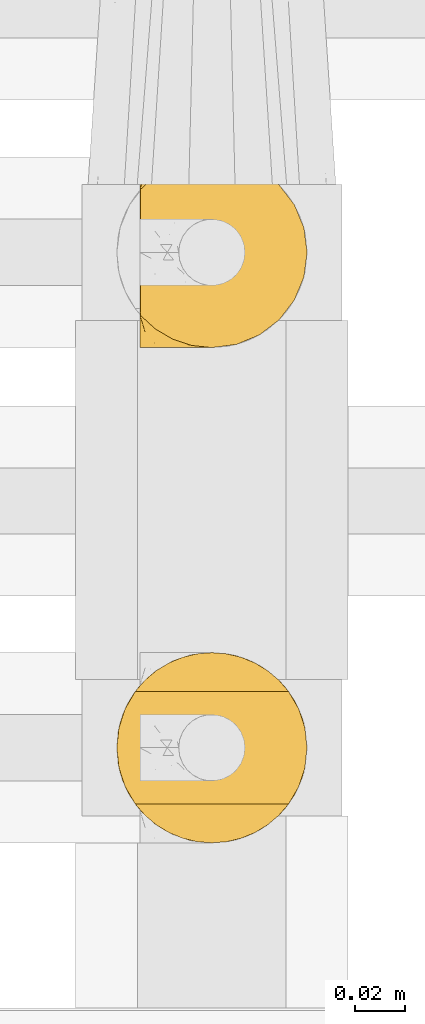
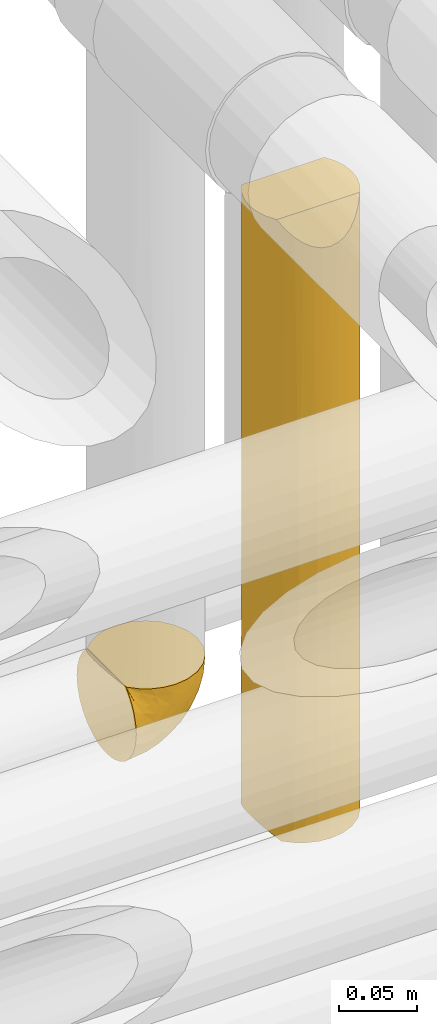
# One storey, part 343 of 827: 2 coverings.
"""IFC2X3 building model written with IfcOpenShell, lengths in millimetres."""

import ifcopenshell
import ifcopenshell.guid

model = None  # the IFC model being written
_history = None  # IfcOwnerHistory: only IFC2X3 demands one
_inside = {}  # id of a spatial element -> (the spatial element, [elements in it])
_under = {}  # id of a project, library or spatial element -> (it, [spatial elements below it])
_declared = {}  # id of a project -> (the project, [libraries it declares])
_typed = {}  # id of a type object -> (the type object, [elements of that type])
_made_of = {}  # id of a material, layer set ... -> (it, [elements and type objects made of it])


def new_model(schema):
    """Start an empty IFC model of exactly this schema.

    Asked for "IFC4X3", IfcOpenShell would pick the latest addendum, in which some entities
    have other attributes; the version numbers below select the first issue.
    IFC2X3 requires an IfcOwnerHistory on every rooted entity: one is made here for all.
    """
    global model, _history
    if schema == "IFC4X3":
        model = ifcopenshell.file(schema_version=(4, 3, 0, 0))
    else:
        model = ifcopenshell.file(schema=schema)
    _inside.clear()
    _under.clear()
    _declared.clear()
    _typed.clear()
    _made_of.clear()
    _history = None
    if model.schema == "IFC2X3":
        org = make("IfcOrganization", Name="unknown")
        user = make(
            "IfcPersonAndOrganization",
            ThePerson=make("IfcPerson", FamilyName="unknown"),
            TheOrganization=org,
        )
        app = make(
            "IfcApplication",
            ApplicationDeveloper=org,
            Version="unknown",
            ApplicationFullName="unknown",
            ApplicationIdentifier="unknown",
        )
        _history = make(
            "IfcOwnerHistory",
            OwningUser=user,
            OwningApplication=app,
            ChangeAction="ADDED",
            CreationDate=0,
        )
    return model


def make(cls, **values):
    """One entity of the class cls with the attributes given. An attribute that is None is left unset."""
    return model.create_entity(
        cls, **{name: value for name, value in values.items() if value is not None}
    )


def entity(cls, *values):
    """Any entity or typed value of the class cls, its attributes in the order of the schema. None: left unset."""
    e = model.create_entity(cls)
    for i, value in enumerate(values):
        if value is not None:
            e[i] = value
    return e


def rooted(cls, **values):
    """An entity with a GlobalId (a new one), such as an element, a storey or a relation."""
    return make(cls, GlobalId=ifcopenshell.guid.new(), OwnerHistory=_history, **values)


def si_unit(unit_type, name, prefix=None):
    """IfcSIUnit, for example si_unit("LENGTHUNIT", "METRE", prefix="MILLI")."""
    return make("IfcSIUnit", UnitType=unit_type, Prefix=prefix, Name=name)


def converted_unit(unit_type, name, factor, base, dimensions=None, offset=None):
    """IfcConversionBasedUnit, such as the inch: factor (a typed value) times the base unit."""
    return make(
        "IfcConversionBasedUnit"
        if offset is None
        else "IfcConversionBasedUnitWithOffset",
        ConversionOffset=offset,
        Dimensions=None
        if dimensions is None
        else entity("IfcDimensionalExponents", *dimensions),
        UnitType=unit_type,
        Name=name,
        ConversionFactor=make(
            "IfcMeasureWithUnit", ValueComponent=factor, UnitComponent=base
        ),
    )


def derived_unit(unit_type, elements):
    """IfcDerivedUnit: a product of units, each with its exponent."""
    return make(
        "IfcDerivedUnit",
        Elements=[
            make("IfcDerivedUnitElement", Unit=unit, Exponent=power)
            for unit, power in elements
        ],
        UnitType=unit_type,
    )


def assignment(units):
    """IfcUnitAssignment: the units of a project."""
    return None if units is None else make("IfcUnitAssignment", Units=units)


def point(xyz):
    """IfcCartesianPoint."""
    return None if xyz is None else make("IfcCartesianPoint", Coordinates=xyz)


def direction(xyz):
    """IfcDirection."""
    return None if xyz is None else make("IfcDirection", DirectionRatios=xyz)


def frame(location, z_axis=None, x_axis=None):
    """IfcAxis2Placement3D, a coordinate frame: its origin and axes. An axis left out is left unset."""
    return make(
        "IfcAxis2Placement3D",
        Location=point(location),
        Axis=direction(z_axis),
        RefDirection=direction(x_axis),
    )


def origin():
    """The frame at (0, 0, 0) with its axes left unset."""
    return frame((0.0, 0.0, 0.0))


def place(relative_to, where):
    """IfcLocalPlacement: puts the frame where relative to a parent placement (None: the world)."""
    return make(
        "IfcLocalPlacement", PlacementRelTo=relative_to, RelativePlacement=where
    )


def context(
    kind, dimensions, precision=None, world=None, true_north=None, identifier=None
):
    """IfcGeometricRepresentationContext, for example the 3D "Model" context."""
    return make(
        "IfcGeometricRepresentationContext",
        ContextIdentifier=identifier,
        ContextType=kind,
        CoordinateSpaceDimension=dimensions,
        Precision=precision,
        WorldCoordinateSystem=world,
        TrueNorth=true_north,
    )


def subcontext(parent, identifier, kind, view, scale=None):
    """IfcGeometricRepresentationSubContext, for example "Body" below "Model"."""
    return make(
        "IfcGeometricRepresentationSubContext",
        ContextIdentifier=identifier,
        ContextType=kind,
        ParentContext=parent,
        TargetScale=scale,
        TargetView=view,
    )


def project(units=None, contexts=None):
    """IfcProject with its units and contexts."""
    return rooted(
        "IfcProject",
        Name="project",
        RepresentationContexts=contexts,
        UnitsInContext=assignment(units),
    )


def spatial(cls, under=None, at=None, **own):
    """A site, building, storey or space (cls), placed at a placement, below another one or the project."""
    s = rooted(cls, ObjectPlacement=at, **own)
    if under is not None:
        _under.setdefault(under.id(), (under, []))[1].append(s)
    return s


def faces_of(points, faces, orient=None, outer=None):
    """IfcFace entities. A face is a list of loops; a loop is a list of indices into points, from 0.

    orient and outer hold one flag for each loop. By default every Orientation is true, the
    first loop of a face is its IfcFaceOuterBound and the others are IfcFaceBound.
    """
    made = []
    for i, loops in enumerate(faces):
        bounds = []
        for j, loop in enumerate(loops):
            is_outer = j == 0 if outer is None else outer[i][j]
            bounds.append(
                make(
                    "IfcFaceOuterBound" if is_outer else "IfcFaceBound",
                    Bound=make("IfcPolyLoop", Polygon=[points[k] for k in loop]),
                    Orientation=True if orient is None else orient[i][j],
                )
            )
        made.append(make("IfcFace", Bounds=bounds))
    return made


def faceted_brep(points, faces, orient=None, outer=None, voids=None):
    """IfcFacetedBrep: a solid bounded by flat faces; with voids (closed shells), ...WithVoids."""
    shared = [point(p) for p in points]
    hull = make("IfcClosedShell", CfsFaces=faces_of(shared, faces, orient, outer))
    if voids is None:
        return make("IfcFacetedBrep", Outer=hull)
    return make(
        "IfcFacetedBrepWithVoids",
        Outer=hull,
        Voids=[
            make(cls, CfsFaces=faces_of(shared, fs, o, b)) for cls, fs, o, b in voids
        ],
    )


def shape(context_of_items, identifier, shape_type, items):
    """IfcShapeRepresentation: the items that make up one representation, for example the "Body"."""
    return make(
        "IfcShapeRepresentation",
        ContextOfItems=context_of_items,
        RepresentationIdentifier=identifier,
        RepresentationType=shape_type,
        Items=items,
    )


def made_of(thing, what):
    """Note that an element or type object is made of a material, layer set ...; save() writes the relation."""
    if what is not None:
        _made_of.setdefault(what.id(), (what, []))[1].append(thing)
    return thing


def element(
    cls,
    number,
    at=None,
    inside=None,
    cuts=None,
    type_object=None,
    material=None,
    context=None,
    identifier="Body",
    shape_type=None,
    held_by="IfcProductDefinitionShape",
    body=None,
    shapes=None,
    **own,
):
    """One element of the class cls, such as IfcWall. Its Tag is "e" and its number.

    at: its placement. inside: the storey or other place that contains it. cuts: it is an
    opening in that element (IfcRelVoidsElement). A single representation is given by context,
    identifier, shape_type and body (its items); several are given by shapes. held_by: the class
    of the entity that holds the representations. save() writes the other relations.
    """
    e = rooted(cls, Tag="e%d" % number, ObjectPlacement=at, **own)
    if body is not None:
        shapes = [shape(context, identifier, shape_type, body)]
    if shapes is not None:
        e.Representation = make(held_by, Representations=shapes)
    if inside is not None:
        _inside.setdefault(inside.id(), (inside, []))[1].append(e)
    if cuts is not None:
        rooted(
            "IfcRelVoidsElement", RelatingBuildingElement=cuts, RelatedOpeningElement=e
        )
    if type_object is not None:
        _typed.setdefault(type_object.id(), (type_object, []))[1].append(e)
    return made_of(e, material)


def aggregate(whole, parts):
    """IfcRelAggregates: a whole, such as a stair, and the parts it consists of."""
    return rooted("IfcRelAggregates", RelatingObject=whole, RelatedObjects=parts)


def save(model, path):
    """Write the relations noted so far, then the file.

    IfcRelAggregates (storeys below a building ...), IfcRelContainedInSpatialStructure (elements
    in a storey), IfcRelDefinesByType, IfcRelAssociatesMaterial and IfcRelDeclares: one each for
    every whole, place, type object, material and project.
    """
    for whole, parts in _under.values():
        aggregate(whole, parts)
    for where, things in _inside.values():
        rooted(
            "IfcRelContainedInSpatialStructure",
            RelatedElements=things,
            RelatingStructure=where,
        )
    for kind, things in _typed.values():
        rooted("IfcRelDefinesByType", RelatedObjects=things, RelatingType=kind)
    for what, things in _made_of.values():
        rooted("IfcRelAssociatesMaterial", RelatedObjects=things, RelatingMaterial=what)
    for by, libraries in _declared.values():
        rooted("IfcRelDeclares", RelatingContext=by, RelatedDefinitions=libraries)
    model.write(path)


model = new_model("IFC2X3")

# Units and contexts
model_context = context("Model", 3, precision=0.01, world=origin(), true_north=direction((6.12303176911189e-17, 1.0)))
body_context = subcontext(model_context, "Body", "Model", "MODEL_VIEW")
ifc_project = project(units=[si_unit("LENGTHUNIT", "METRE", prefix="MILLI"), si_unit("AREAUNIT", "SQUARE_METRE"), si_unit("VOLUMEUNIT", "CUBIC_METRE"), converted_unit("PLANEANGLEUNIT", "DEGREE", entity("IfcRatioMeasure", 0.0174532925199433), si_unit("PLANEANGLEUNIT", "RADIAN"), dimensions=[0, 0, 0, 0, 0, 0, 0]), si_unit("MASSUNIT", "GRAM", prefix="KILO"), derived_unit("MASSDENSITYUNIT", [(si_unit("MASSUNIT", "GRAM", prefix="KILO"), 1), (si_unit("LENGTHUNIT", "METRE"), -3)]), derived_unit("MOMENTOFINERTIAUNIT", [(si_unit("LENGTHUNIT", "METRE"), 4)]), si_unit("TIMEUNIT", "SECOND"), si_unit("FREQUENCYUNIT", "HERTZ"), si_unit("THERMODYNAMICTEMPERATUREUNIT", "DEGREE_CELSIUS"), derived_unit("THERMALTRANSMITTANCEUNIT", [(si_unit("MASSUNIT", "GRAM", prefix="KILO"), 1), (si_unit("THERMODYNAMICTEMPERATUREUNIT", "KELVIN"), -1), (si_unit("TIMEUNIT", "SECOND"), -3)]), derived_unit("VOLUMETRICFLOWRATEUNIT", [(si_unit("LENGTHUNIT", "METRE"), 3), (si_unit("TIMEUNIT", "SECOND"), -1)]), derived_unit("MASSFLOWRATEUNIT", [(si_unit("MASSUNIT", "GRAM", prefix="KILO"), 1), (si_unit("TIMEUNIT", "SECOND"), -1)]), derived_unit("ROTATIONALFREQUENCYUNIT", [(si_unit("TIMEUNIT", "SECOND"), -1)]), si_unit("ELECTRICCURRENTUNIT", "AMPERE"), si_unit("ELECTRICVOLTAGEUNIT", "VOLT"), si_unit("POWERUNIT", "WATT"), si_unit("FORCEUNIT", "NEWTON", prefix="KILO"), si_unit("ILLUMINANCEUNIT", "LUX"), si_unit("LUMINOUSFLUXUNIT", "LUMEN"), si_unit("LUMINOUSINTENSITYUNIT", "CANDELA"), derived_unit("USERDEFINED", [(si_unit("MASSUNIT", "GRAM", prefix="KILO"), -1), (si_unit("LENGTHUNIT", "METRE"), -2), (si_unit("TIMEUNIT", "SECOND"), 3), (si_unit("LUMINOUSFLUXUNIT", "LUMEN"), 1)]), derived_unit("LINEARVELOCITYUNIT", [(si_unit("LENGTHUNIT", "METRE"), 1), (si_unit("TIMEUNIT", "SECOND"), -1)]), si_unit("PRESSUREUNIT", "PASCAL"), derived_unit("USERDEFINED", [(si_unit("LENGTHUNIT", "METRE"), -2), (si_unit("MASSUNIT", "GRAM", prefix="KILO"), 1), (si_unit("TIMEUNIT", "SECOND"), -2)]), derived_unit("LINEARFORCEUNIT", [(si_unit("MASSUNIT", "GRAM", prefix="KILO"), 1), (si_unit("LENGTHUNIT", "METRE"), 1), (si_unit("TIMEUNIT", "SECOND"), -2), (si_unit("LENGTHUNIT", "METRE"), -1)]), derived_unit("PLANARFORCEUNIT", [(si_unit("MASSUNIT", "GRAM", prefix="KILO"), 1), (si_unit("LENGTHUNIT", "METRE"), 1), (si_unit("TIMEUNIT", "SECOND"), -2), (si_unit("LENGTHUNIT", "METRE"), -2)])], contexts=[model_context])

# Site, building, storey
site_placement = place(None, origin())
site = spatial("IfcSite", under=ifc_project, at=site_placement, CompositionType="ELEMENT")
building_placement = place(site_placement, origin())
building = spatial("IfcBuilding", under=site, at=building_placement, CompositionType="ELEMENT")
storey_placement = place(building_placement, frame((0.0, 0.0, 28200.0)))
storey = spatial("IfcBuildingStorey", under=building, at=storey_placement, Name="08", CompositionType="ELEMENT", Elevation=28200.0)

# Coverings
covering_1_placement = place(storey_placement, frame((36438.02, 15449.95, 2959.95)))
element("IfcCovering", 1, at=covering_1_placement, inside=storey, Name=":ADSK_", ObjectType=":ADSK_", PredefinedType="INSULATION", context=body_context, shape_type="Brep", body=[
    faceted_brep([(1.6, 74.68, 23.36), (1.6, 70.1, 16.07), (1.6, 64.01, 9.98), (1.6, 56.72, 5.4), (1.6, 48.6, 2.56), (1.6, 40.05, 1.6), (1.6, 31.49, 2.56), (1.6, 23.36, 5.41), (1.6, 16.07, 9.99), (1.6, 9.98, 16.08), (1.6, 5.4, 23.37), (1.6, 2.56, 31.49), (1.6, 1.6, 40.05), (1.6, 2.46, 48.15), (1.6, 5.01, 55.88), (1.6, 9.13, 62.9), (1.6, 14.62, 68.89), (1.6, 16.82, 68.89), (1.6, 18.56, 68.89), (1.6, 20.52, 68.89), (1.6, 22.49, 68.89), (1.6, 24.46, 68.89), (1.6, 26.42, 68.89), (1.6, 28.39, 68.89), (1.6, 30.36, 68.89), (1.6, 32.55, 68.89), (1.6, 34.75, 68.89), (1.6, 36.94, 68.89), (1.6, 39.13, 68.89), (1.6, 41.33, 68.89), (1.6, 43.52, 68.89), (1.6, 45.72, 68.89), (1.6, 47.91, 68.89), (1.6, 50.11, 68.89), (1.6, 52.3, 68.89), (1.6, 54.49, 68.89), (1.6, 56.69, 68.89), (1.6, 58.88, 68.89), (1.6, 61.08, 68.89), (1.6, 63.27, 68.89), (1.6, 65.47, 68.89), (1.6, 70.97, 62.89), (1.6, 75.09, 55.86), (1.6, 77.64, 48.13), (1.6, 78.5, 40.05), (1.6, 77.53, 31.49), (1.85, 14.62, 69.15), (7.85, 9.12, 69.15), (14.87, 5.0, 69.15), (22.6, 2.46, 69.15), (30.7, 1.6, 69.15), (40.65, 2.91, 69.15), (49.92, 6.75, 69.15), (57.88, 12.86, 69.15), (63.99, 20.82, 69.15), (67.84, 30.09, 69.15), (69.15, 40.05, 69.15), (67.84, 50.0, 69.15), (63.99, 59.27, 69.15), (57.88, 67.23, 69.15), (49.92, 73.34, 69.15), (40.65, 77.19, 69.15), (30.7, 78.5, 69.15), (22.6, 77.63, 69.15), (14.87, 75.09, 69.15), (7.85, 70.97, 69.15), (1.85, 65.47, 69.15), (1.85, 63.27, 69.15), (1.85, 62.29, 69.15), (1.85, 60.7, 69.15), (1.85, 59.11, 69.15), (1.85, 57.52, 69.15), (1.85, 55.93, 69.15), (1.85, 54.34, 69.15), (1.85, 52.76, 69.15), (1.85, 51.17, 69.15), (1.85, 49.58, 69.15), (1.85, 47.99, 69.15), (1.85, 46.4, 69.15), (1.85, 44.81, 69.15), (1.85, 43.22, 69.15), (1.85, 41.63, 69.15), (1.85, 40.05, 69.15), (1.85, 38.46, 69.15), (1.85, 36.87, 69.15), (1.85, 35.28, 69.15), (1.85, 33.69, 69.15), (1.85, 32.1, 69.15), (1.85, 30.51, 69.15), (1.85, 28.92, 69.15), (1.85, 27.33, 69.15), (1.85, 25.37, 69.15), (1.85, 23.4, 69.15), (1.85, 21.21, 69.15), (1.85, 19.01, 69.15), (1.85, 16.82, 69.15), (1.77, 42.32, 68.96), (1.78, 44.02, 68.97), (1.77, 47.13, 68.97), (1.77, 48.74, 68.97), (1.76, 23.57, 68.95), (1.77, 25.13, 68.96), (1.79, 61.34, 68.98), (1.78, 22.02, 68.97), (1.78, 29.72, 68.97), (1.78, 56.73, 68.98), (1.78, 55.14, 68.97), (1.78, 37.66, 68.97), (1.74, 64.12, 68.94), (1.78, 28.13, 68.98), (1.78, 26.62, 68.98), (1.77, 31.46, 68.96), (1.78, 16.16, 68.97), (1.78, 39.16, 68.98), (1.78, 50.37, 68.98), (1.77, 17.69, 68.97), (1.77, 19.17, 68.96), (1.77, 62.78, 68.97), (1.78, 58.35, 68.97), (1.78, 45.53, 68.98), (1.77, 59.91, 68.96), (1.77, 65.47, 68.97), (1.72, 65.47, 68.94), (1.66, 65.47, 68.92), (1.77, 14.62, 68.97), (1.8, 14.62, 69.02), (1.82, 14.62, 69.08), (1.79, 20.59, 68.98), (1.78, 32.99, 68.97), (1.79, 34.48, 68.98), (1.78, 51.91, 68.97), (1.82, 65.47, 69.08), (1.8, 65.47, 69.02), (1.76, 53.48, 68.96), (1.66, 14.62, 68.92), (1.72, 14.62, 68.94), (1.78, 40.77, 68.97), (1.77, 35.97, 68.96), (9.41, 7.84, 67.02), (17.65, 3.53, 63.33), (7.41, 8.32, 64.61), (15.21, 2.19, 51.4), (7.41, 3.53, 53.1), (16.15, 1.6, 43.94), (28.75, 1.6, 61.87), (13.67, 4.57, 61.54), (12.79, 3.96, 57.95), (19.18, 2.28, 56.12), (29.16, 1.6, 63.4), (9.04, 7.69, 65.41), (5.74, 8.32, 63.04), (3.72, 7.84, 61.33), (8.87, 1.6, 41.99), (21.47, 1.6, 49.27), (26.8, 1.6, 54.6), (9.53, 4.34, 56.6), (7.34, 1.6, 41.58), (37.63, 29.63, 13.72), (17.92, 27.34, 5.82), (27.45, 40.05, 6.74), (37.01, 2.39, 58.82), (34.22, 2.43, 51.58), (45.87, 9.07, 42.09), (56.57, 16.64, 46.12), (52.31, 9.54, 55.56), (42.07, 4.52, 52.38), (44.74, 4.52, 61.54), (21.49, 7.49, 23.76), (11.02, 7.49, 20.5), (15.64, 12.85, 14.64), (26.02, 2.35, 41.77), (36.59, 22.66, 16.28), (65.49, 32.9, 49.4), (63.99, 25.33, 52.34), (15.2, 40.05, 4.3), (60.27, 16.64, 58.67), (45.25, 19.99, 25.26), (35.21, 16.37, 20.17), (22.52, 3.26, 34.7), (12.03, 3.75, 28.67), (13.32, 19.58, 8.62), (35.9, 7.5, 33.37), (33.87, 4.04, 41.35), (25.73, 13.94, 17.15), (26.34, 19.58, 12.68), (46.78, 28.21, 21.47), (59.54, 24.75, 41.11), (60.18, 31.42, 37.53), (53.93, 26.2, 30.64), (53.36, 33.36, 26.66), (49.36, 40.05, 21.38), (38.4, 40.05, 14.06), (66.44, 40.05, 55.54), (50.09, 16.14, 35.17), (41.08, 12.85, 29.04), (31.14, 10.47, 24.34), (28.19, 6.49, 29.33), (64.0, 40.05, 43.3), (56.68, 40.05, 32.34), (43.9, 75.57, 57.75), (65.46, 47.37, 49.41), (52.22, 52.91, 27.85), (37.61, 50.46, 13.7), (15.64, 67.23, 14.63), (13.31, 60.5, 8.61), (50.02, 70.55, 48.85), (59.28, 63.45, 54.13), (53.05, 62.61, 37.84), (21.48, 72.6, 23.75), (11.01, 72.6, 20.49), (12.03, 76.34, 28.66), (41.02, 59.34, 20.83), (35.39, 77.76, 55.15), (26.8, 78.5, 54.6), (28.75, 78.5, 61.87), (7.34, 78.5, 41.58), (65.81, 53.16, 57.58), (53.28, 70.55, 59.91), (59.8, 48.88, 36.94), (61.82, 54.76, 45.72), (17.91, 52.74, 5.82), (41.4, 71.93, 37.91), (40.48, 75.79, 50.18), (26.34, 60.5, 12.67), (31.68, 77.86, 49.29), (27.68, 77.64, 42.64), (16.15, 78.5, 43.94), (21.47, 78.5, 49.27), (28.05, 67.23, 19.45), (22.54, 76.82, 34.7), (8.87, 78.5, 41.99), (37.3, 77.8, 62.29), (41.07, 67.23, 29.01), (32.24, 73.2, 31.47), (47.4, 67.66, 37.18), (35.77, 75.99, 43.45), (17.65, 76.57, 63.33), (11.06, 73.21, 67.23), (8.55, 71.93, 66.07), (6.63, 71.07, 65.22), (12.77, 75.09, 61.99), (12.79, 76.13, 57.95), (7.41, 76.57, 53.09), (18.97, 77.69, 56.84), (3.72, 72.26, 61.33), (5.76, 71.77, 63.06), (15.21, 77.9, 51.41), (9.52, 75.75, 56.61)], [[[0, 1, 2, 3, 4, 5, 6, 7, 8, 9, 10, 11, 12, 13, 14, 15, 16, 17, 18, 19, 20, 21, 22, 23, 24, 25, 26, 27, 28, 29, 30, 31, 32, 33, 34, 35, 36, 37, 38, 39, 40, 41, 42, 43, 44, 45]], [[46, 47, 48, 49, 50, 51, 52, 53, 54, 55, 56, 57, 58, 59, 60, 61, 62, 63, 64, 65, 66, 67, 68, 69, 70, 71, 72, 73, 74, 75, 76, 77, 78, 79, 80, 81, 82, 83, 84, 85, 86, 87, 88, 89, 90, 91, 92, 93, 94, 95]], [[96, 97, 30]], [[98, 77, 99]], [[100, 101, 21]], [[69, 68, 102]], [[20, 19, 103]], [[24, 23, 104]], [[20, 103, 100]], [[72, 105, 106]], [[84, 83, 107]], [[89, 88, 104]], [[108, 67, 66]], [[109, 110, 90]], [[111, 25, 24]], [[112, 17, 16]], [[82, 113, 83]], [[109, 23, 22]], [[114, 76, 75]], [[105, 36, 106]], [[104, 111, 24]], [[18, 115, 116]], [[97, 96, 80]], [[67, 108, 117]], [[105, 71, 118]], [[31, 97, 119]], [[102, 120, 69]], [[108, 121, 122, 123, 40]], [[112, 95, 115]], [[17, 115, 18]], [[94, 116, 115]], [[117, 68, 67]], [[38, 117, 39]], [[112, 124, 125, 126, 46]], [[17, 112, 115]], [[70, 120, 118]], [[39, 117, 108]], [[120, 38, 37]], [[120, 37, 118]], [[120, 70, 69]], [[116, 94, 127]], [[128, 86, 129]], [[117, 38, 102]], [[74, 130, 75]], [[99, 33, 32]], [[115, 95, 94]], [[39, 108, 40]], [[108, 66, 131, 132, 121]], [[105, 72, 71]], [[118, 37, 36]], [[71, 70, 118]], [[35, 106, 36]], [[36, 105, 118]], [[35, 133, 106]], [[74, 73, 133]], [[106, 133, 73]], [[99, 114, 33]], [[133, 35, 34]], [[73, 72, 106]], [[95, 112, 46]], [[112, 16, 134, 135, 124]], [[130, 114, 75]], [[99, 76, 114]], [[114, 130, 33]], [[34, 33, 130]], [[78, 77, 98]], [[98, 119, 78]], [[130, 133, 34]], [[133, 130, 74]], [[79, 97, 80]], [[98, 99, 32]], [[98, 32, 31]], [[77, 76, 99]], [[97, 79, 119]], [[136, 96, 29]], [[30, 97, 31]], [[136, 29, 28]], [[81, 80, 96]], [[29, 96, 30]], [[31, 119, 98]], [[119, 79, 78]], [[96, 136, 81]], [[82, 81, 136]], [[113, 107, 83]], [[84, 107, 137]], [[107, 27, 137]], [[113, 28, 107]], [[27, 107, 28]], [[85, 84, 137]], [[137, 27, 26]], [[113, 136, 28]], [[136, 113, 82]], [[109, 89, 104]], [[86, 85, 129]], [[89, 109, 90]], [[111, 87, 128]], [[26, 129, 137]], [[88, 111, 104]], [[25, 111, 128]], [[22, 110, 109]], [[23, 109, 104]], [[110, 91, 90]], [[100, 92, 101]], [[110, 22, 101]], [[91, 110, 101]], [[116, 19, 18]], [[111, 88, 87]], [[127, 103, 19]], [[25, 128, 26]], [[86, 128, 87]], [[128, 129, 26]], [[137, 129, 85]], [[120, 102, 38]], [[117, 102, 68]], [[91, 101, 92]], [[21, 101, 22]], [[93, 92, 103]], [[100, 21, 20]], [[100, 103, 92]], [[127, 93, 103]], [[93, 127, 94]], [[116, 127, 19]], [[126, 138, 47]], [[48, 138, 139]], [[140, 125, 124]], [[141, 142, 143]], [[144, 49, 139]], [[145, 140, 146]], [[48, 139, 49]], [[139, 145, 147]], [[49, 144, 148, 50]], [[126, 125, 149]], [[14, 13, 142]], [[150, 146, 140]], [[149, 140, 145]], [[151, 150, 135]], [[151, 14, 142]], [[16, 15, 134]], [[13, 152, 142]], [[124, 150, 140]], [[141, 143, 153]], [[14, 151, 15]], [[15, 151, 134]], [[47, 46, 126]], [[139, 154, 144]], [[138, 48, 47]], [[125, 140, 149]], [[135, 134, 151]], [[146, 155, 141]], [[145, 146, 147]], [[149, 139, 138]], [[147, 153, 154]], [[147, 146, 141]], [[139, 147, 154]], [[139, 149, 145]], [[149, 138, 126]], [[147, 141, 153]], [[146, 150, 155]], [[151, 155, 150]], [[142, 141, 155]], [[13, 12, 156, 152]], [[152, 143, 142]], [[151, 142, 155]], [[150, 124, 135]], [[157, 158, 159]], [[160, 154, 161]], [[162, 163, 164]], [[165, 166, 160]], [[167, 168, 169]], [[153, 170, 161]], [[156, 12, 11]], [[158, 157, 171]], [[172, 55, 173]], [[158, 6, 174]], [[175, 54, 53]], [[52, 166, 164]], [[52, 164, 53]], [[54, 175, 173]], [[166, 52, 51]], [[176, 177, 171]], [[178, 143, 179]], [[156, 11, 179]], [[8, 7, 180]], [[169, 9, 8]], [[179, 143, 152, 156]], [[179, 11, 10]], [[168, 179, 10]], [[181, 162, 182]], [[179, 167, 178]], [[183, 184, 177]], [[183, 169, 184]], [[176, 171, 185]], [[172, 186, 187]], [[158, 7, 6]], [[159, 158, 174]], [[184, 180, 158]], [[54, 173, 55]], [[180, 169, 8]], [[188, 189, 187]], [[9, 168, 10]], [[186, 188, 187]], [[190, 157, 159, 191]], [[55, 172, 192]], [[176, 193, 194]], [[161, 170, 182]], [[162, 164, 165]], [[175, 164, 163]], [[51, 50, 148]], [[167, 195, 196]], [[178, 182, 170]], [[6, 5, 174]], [[158, 180, 7]], [[169, 180, 184]], [[169, 168, 9]], [[179, 168, 167]], [[182, 162, 165]], [[162, 194, 193]], [[161, 165, 160]], [[195, 181, 196]], [[192, 172, 197]], [[192, 56, 55]], [[189, 190, 198]], [[198, 197, 187]], [[172, 187, 197]], [[185, 189, 188]], [[198, 187, 189]], [[186, 172, 173]], [[173, 163, 186]], [[193, 186, 163]], [[176, 185, 188]], [[185, 157, 190]], [[188, 186, 193]], [[177, 176, 194]], [[188, 193, 176]], [[162, 193, 163]], [[195, 177, 194]], [[171, 177, 184]], [[181, 195, 194]], [[183, 167, 169]], [[162, 181, 194]], [[196, 182, 178]], [[158, 171, 184]], [[171, 157, 185]], [[177, 195, 183]], [[167, 183, 195]], [[182, 196, 181]], [[178, 170, 143]], [[178, 167, 196]], [[164, 175, 53]], [[173, 175, 163]], [[160, 51, 148]], [[164, 166, 165]], [[51, 160, 166]], [[160, 148, 144, 154]], [[153, 161, 154]], [[182, 165, 161]], [[190, 189, 185]], [[143, 170, 153]], [[60, 199, 61]], [[197, 200, 192]], [[201, 190, 202]], [[200, 57, 192]], [[203, 204, 2]], [[205, 206, 207]], [[208, 209, 210]], [[211, 207, 201]], [[212, 213, 214]], [[45, 215, 210]], [[216, 206, 58]], [[45, 44, 215]], [[59, 217, 60]], [[60, 217, 199]], [[0, 45, 210]], [[218, 201, 219]], [[202, 159, 220]], [[205, 221, 222]], [[223, 204, 203]], [[1, 203, 2]], [[57, 200, 216]], [[220, 3, 204]], [[220, 174, 4]], [[1, 0, 209]], [[212, 224, 213]], [[225, 226, 227]], [[228, 223, 203]], [[208, 210, 229]], [[210, 226, 229]], [[3, 220, 4]], [[58, 206, 59]], [[209, 203, 1]], [[202, 220, 223]], [[228, 203, 208]], [[202, 211, 201]], [[3, 2, 204]], [[202, 190, 191, 159]], [[210, 215, 230, 226]], [[199, 212, 231]], [[232, 233, 221]], [[233, 208, 229]], [[207, 206, 219]], [[217, 206, 205]], [[227, 224, 225]], [[233, 232, 228]], [[201, 207, 219]], [[234, 232, 221]], [[218, 219, 200]], [[202, 223, 211]], [[174, 220, 159]], [[174, 5, 4]], [[61, 231, 62]], [[220, 204, 223]], [[210, 209, 0]], [[203, 209, 208]], [[225, 233, 229]], [[224, 227, 213]], [[221, 233, 235]], [[57, 56, 192]], [[198, 218, 197]], [[200, 219, 216]], [[201, 198, 190]], [[197, 218, 200]], [[198, 201, 218]], [[206, 216, 219]], [[58, 57, 216]], [[231, 212, 214]], [[222, 212, 199]], [[228, 211, 223]], [[207, 211, 232]], [[62, 231, 214]], [[199, 231, 61]], [[233, 228, 208]], [[211, 228, 232]], [[222, 221, 235]], [[234, 205, 207]], [[206, 217, 59]], [[199, 217, 205]], [[205, 222, 199]], [[224, 222, 235]], [[222, 224, 212]], [[224, 235, 225]], [[233, 225, 235]], [[226, 225, 229]], [[205, 234, 221]], [[207, 232, 234]], [[63, 214, 236]], [[214, 213, 236]], [[214, 63, 62]], [[237, 236, 238]], [[238, 132, 131]], [[236, 237, 64]], [[239, 240, 241]], [[63, 236, 64]], [[131, 66, 65]], [[237, 131, 65]], [[242, 230, 43]], [[237, 65, 64]], [[239, 121, 132]], [[42, 242, 43]], [[241, 240, 243]], [[41, 123, 244]], [[43, 230, 215, 44]], [[244, 122, 245]], [[227, 246, 243]], [[241, 247, 245]], [[121, 239, 245]], [[41, 40, 123]], [[132, 238, 239]], [[244, 42, 41]], [[131, 237, 238]], [[240, 239, 238]], [[245, 239, 241]], [[247, 241, 246]], [[247, 244, 245]], [[238, 236, 240]], [[243, 236, 213]], [[236, 243, 240]], [[227, 226, 246]], [[243, 213, 227]], [[242, 246, 226]], [[243, 246, 241]], [[246, 242, 247]], [[244, 247, 242]], [[242, 226, 230]], [[42, 244, 242]], [[122, 244, 123]], [[122, 121, 245]]]),
])
covering_2_placement = place(storey_placement, frame((36428.72, 15250.0, 3027.5)))
element("IfcCovering", 2, at=covering_2_placement, inside=storey, Name=":ADSK_", ObjectType=":ADSK_", PredefinedType="INSULATION", context=body_context, shape_type="Brep", body=[
    faceted_brep([(16.91, 9.31, 1.6), (10.9, 14.94, 1.6), (10.9, 65.05, 1.6), (16.91, 70.68, 1.6), (23.98, 74.9, 1.6), (31.79, 77.51, 1.6), (40.0, 78.4, 1.6), (49.93, 77.09, 1.6), (59.2, 73.25, 1.6), (67.15, 67.15, 1.6), (73.25, 59.2, 1.6), (77.09, 49.93, 1.6), (78.4, 40.0, 1.6), (77.09, 30.06, 1.6), (73.25, 20.8, 1.6), (67.15, 12.84, 1.6), (59.2, 6.74, 1.6), (49.93, 2.9, 1.6), (40.0, 1.6, 1.6), (31.79, 2.48, 1.6), (23.98, 5.09, 1.6), (2.45, 31.93, 490.0), (4.98, 24.24, 490.0), (9.06, 17.25, 490.0), (70.93, 17.25, 490.0), (75.01, 24.24, 490.0), (77.54, 31.93, 490.0), (78.4, 40.0, 490.0), (77.54, 48.06, 490.0), (75.01, 55.75, 490.0), (70.93, 62.75, 490.0), (9.06, 62.75, 490.0), (4.98, 55.75, 490.0), (2.45, 48.06, 490.0), (1.6, 40.0, 490.0), (6.04, 22.05, 259.03), (19.86, 7.3, 235.42), (31.0, 2.66, 242.84), (10.73, 15.13, 251.9), (17.54, 8.84, 477.99), (12.97, 12.71, 483.52), (40.0, 1.6, 251.27), (22.66, 5.73, 473.55), (2.97, 29.81, 243.75), (4.0, 26.63, 8.5), (34.02, 2.06, 468.31), (40.0, 1.6, 467.64), (1.6, 40.0, 250.44), (28.2, 3.45, 470.29), (2.2, 33.21, 10.29), (6.92, 20.48, 5.57), (1.6, 40.0, 227.27), (1.6, 40.0, 10.9), (2.97, 50.18, 243.75), (2.2, 46.78, 10.29), (8.88, 62.5, 236.9), (28.2, 76.54, 470.29), (34.02, 77.93, 468.31), (32.49, 77.66, 220.4), (5.36, 56.58, 187.01), (4.0, 53.36, 8.5), (6.92, 59.51, 5.57), (40.0, 78.4, 467.64), (40.0, 78.4, 251.27), (14.98, 69.13, 243.74), (12.97, 67.28, 483.52), (17.54, 71.15, 477.99), (25.25, 75.45, 243.03), (22.66, 74.26, 473.55), (54.76, 75.45, 223.03), (47.46, 77.66, 209.58), (78.4, 40.0, 273.62), (76.48, 51.97, 255.92), (57.33, 74.26, 473.55), (62.33, 71.23, 227.69), (73.48, 58.8, 294.68), (62.45, 71.15, 477.99), (51.79, 76.54, 470.29), (45.97, 77.93, 468.31), (69.27, 64.85, 243.58), (67.02, 67.28, 483.52), (76.48, 28.02, 255.92), (73.48, 21.19, 294.68), (47.46, 2.33, 209.58), (69.27, 15.14, 243.58), (45.97, 2.06, 468.31), (67.02, 12.71, 483.52), (62.33, 8.76, 227.69), (62.45, 8.84, 477.99), (51.79, 3.45, 470.29), (54.76, 4.55, 223.03), (57.33, 5.73, 473.55)], [[[0, 1, 2, 3, 4, 5, 6, 7, 8, 9, 10, 11, 12, 13, 14, 15, 16, 17, 18, 19, 20]], [[21, 22, 23, 24, 25, 26, 27, 28, 29, 30, 31, 32, 33, 34]], [[23, 22, 35]], [[36, 20, 37]], [[38, 39, 40]], [[18, 41, 19]], [[0, 20, 36]], [[36, 37, 42]], [[35, 43, 44]], [[41, 45, 37]], [[46, 45, 41]], [[20, 19, 37]], [[47, 21, 34]], [[41, 37, 19]], [[39, 36, 42]], [[23, 35, 38]], [[39, 38, 36]], [[48, 42, 37]], [[38, 40, 23]], [[22, 21, 43]], [[43, 35, 22]], [[43, 47, 49]], [[44, 50, 35]], [[1, 38, 50]], [[37, 45, 48]], [[49, 44, 43]], [[21, 47, 43]], [[38, 1, 0]], [[50, 38, 35]], [[0, 36, 38]], [[49, 47, 51, 52]], [[33, 51, 47, 34]], [[51, 53, 54]], [[32, 31, 55]], [[56, 57, 58]], [[51, 33, 53]], [[32, 55, 59]], [[53, 59, 60]], [[2, 61, 55]], [[57, 62, 63]], [[53, 60, 54]], [[60, 59, 61]], [[64, 55, 65]], [[65, 66, 64]], [[67, 4, 3]], [[67, 66, 68]], [[2, 64, 3]], [[57, 63, 58]], [[68, 56, 67]], [[54, 52, 51]], [[66, 67, 64]], [[32, 59, 53]], [[67, 3, 64]], [[58, 6, 5]], [[4, 67, 5]], [[6, 58, 63]], [[58, 67, 56]], [[67, 58, 5]], [[61, 59, 55]], [[32, 53, 33]], [[55, 64, 2]], [[55, 31, 65]], [[69, 7, 70]], [[71, 11, 72]], [[69, 73, 74]], [[75, 30, 29]], [[8, 7, 69]], [[74, 73, 76]], [[77, 70, 78]], [[28, 27, 71]], [[78, 63, 62]], [[73, 69, 77]], [[63, 70, 6]], [[8, 69, 74]], [[10, 9, 79]], [[29, 72, 75]], [[29, 28, 72]], [[6, 70, 7]], [[78, 70, 63]], [[71, 12, 11]], [[74, 80, 79]], [[30, 79, 80]], [[9, 8, 74]], [[79, 75, 10]], [[10, 75, 72]], [[9, 74, 79]], [[71, 72, 28]], [[80, 74, 76]], [[30, 75, 79]], [[77, 69, 70]], [[10, 72, 11]], [[71, 26, 81]], [[81, 25, 82]], [[18, 83, 41]], [[24, 84, 82]], [[85, 46, 41]], [[26, 71, 27]], [[71, 81, 13]], [[81, 14, 13]], [[86, 84, 24]], [[12, 71, 13]], [[87, 86, 88]], [[15, 84, 87]], [[89, 85, 83]], [[89, 90, 91]], [[14, 81, 82]], [[17, 16, 90]], [[90, 87, 91]], [[86, 87, 84]], [[16, 87, 90]], [[83, 17, 90]], [[15, 14, 84]], [[14, 82, 84]], [[83, 18, 17]], [[81, 26, 25]], [[24, 82, 25]], [[41, 83, 85]], [[91, 87, 88]], [[83, 90, 89]], [[15, 87, 16]], [[52, 54, 60, 61, 2, 1, 50, 44, 49]], [[68, 66, 65, 31, 30, 80, 76, 73, 77, 78, 62, 57, 56]], [[91, 88, 86, 24, 23, 40, 39, 42, 48, 45, 46, 85, 89]]]),
])

save(model, "model.ifc")
